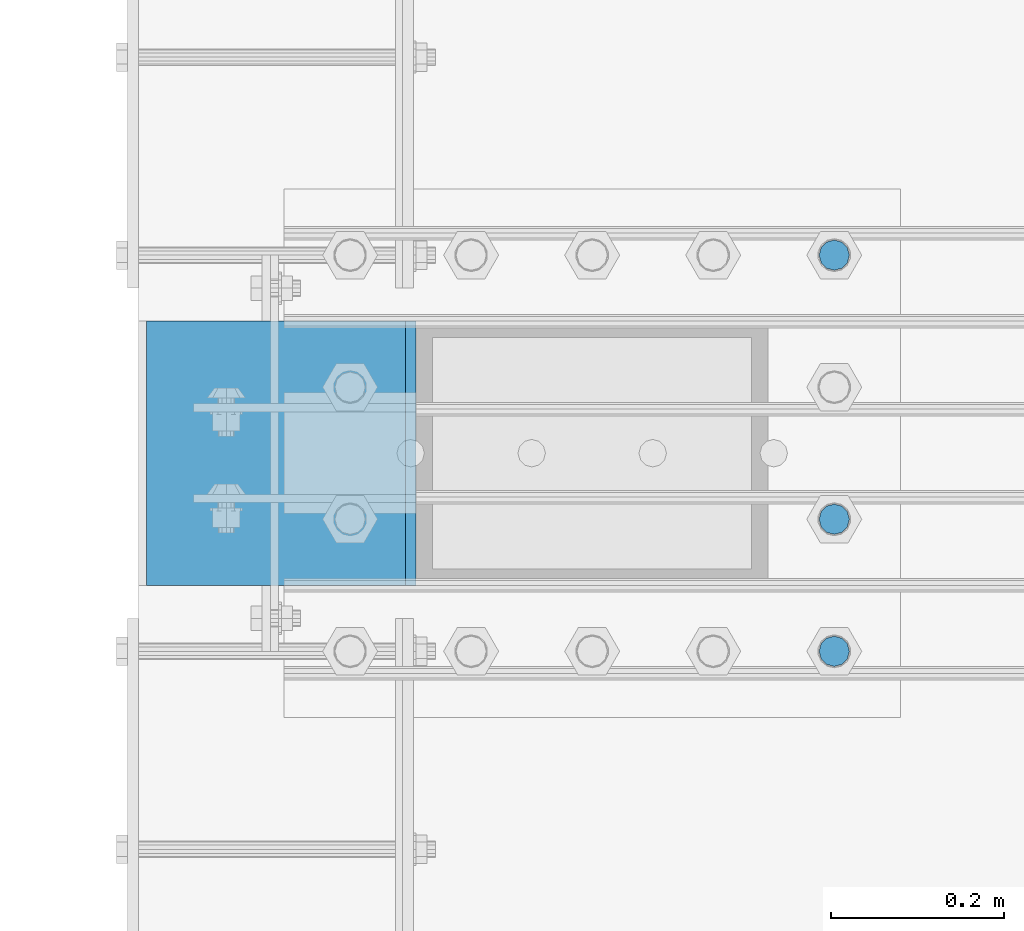
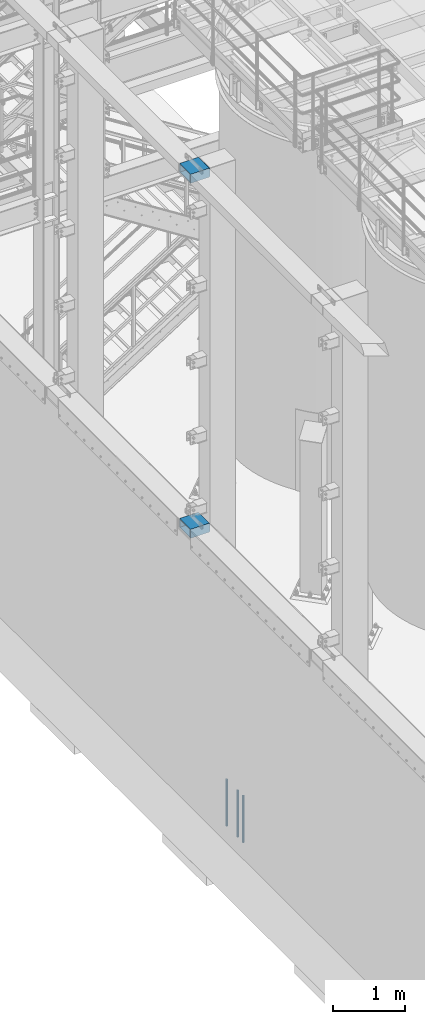
# One storey, part 1098 of 1876: 5 beams, 2 elements without a shape of their own.
"""IFC2X3 building model written with IfcOpenShell, lengths in millimetres."""

from ifc_helpers import new_model, si_unit, frame, origin_with_axes, place, context, subcontext, project, spatial, faceted_brep, material, type_object, element, aggregate, save


model = new_model("IFC2X3")

# Units and contexts
model_context = context("Model", 3, precision=1e-05, world=origin_with_axes())
body_context = subcontext(model_context, "Body", "Model", "MODEL_VIEW")
ifc_project = project(units=[si_unit("LENGTHUNIT", "METRE", prefix="MILLI"), si_unit("AREAUNIT", "SQUARE_METRE"), si_unit("VOLUMEUNIT", "CUBIC_METRE"), si_unit("MASSUNIT", "GRAM", prefix="KILO"), si_unit("TIMEUNIT", "SECOND"), si_unit("PLANEANGLEUNIT", "RADIAN"), si_unit("SOLIDANGLEUNIT", "STERADIAN"), si_unit("THERMODYNAMICTEMPERATUREUNIT", "DEGREE_CELSIUS"), si_unit("LUMINOUSINTENSITYUNIT", "LUMEN")], contexts=[model_context])

# Site, building, storey
site_placement = place(None, origin_with_axes())
site = spatial("IfcSite", under=ifc_project, at=site_placement, CompositionType="ELEMENT")
building_placement = place(site_placement, origin_with_axes())
building = spatial("IfcBuilding", under=site, at=building_placement, Name="Undefined", CompositionType="ELEMENT")
storey_placement = place(building_placement, origin_with_axes())
storey = spatial("IfcBuildingStorey", under=building, at=storey_placement, Name="Undefined", CompositionType="ELEMENT", Elevation=0.0)

# Assembly, beams
assembly_1_placement = place(storey_placement, origin_with_axes())
assembly_1 = element("IfcElementAssembly", 1, at=assembly_1_placement, inside=storey, Name="COLUMN", AssemblyPlace="NOTDEFINED", PredefinedType="RIGID_FRAME")
ifc_material_1 = material()
beam_type_1 = type_object("IfcBeamType", Name="HSS12X6X1/2", PredefinedType="NOTDEFINED")
beam_1_placement = place(assembly_1_placement, frame((-301.625, -14427.2, 10591.8), z_axis=(0.0, 1.0, 0.0), x_axis=(1.0, 0.0, 0.0)))
beam_1 = element("IfcBeam", 2, at=beam_1_placement, type_object=beam_type_1, material=ifc_material_1, Name="BEAM", ObjectType="HSS12X6X1/2", context=body_context, shape_type="Brep", body=[
    faceted_brep([(330.199999999997, 63.4999999999982, 152.4), (330.200000000004, 63.5, 139.7), (330.200000000004, 63.5, -139.7), (330.200000000004, 63.4999999999982, -152.4), (318.105151367185, 76.2000000000007, -152.4), (318.105151367185, 76.2000000000007, 152.4), (19.0499999999993, -76.2000000000007, 152.4), (19.0499999999993, -76.2000000000007, -152.4), (318.105151367185, -76.2000000000007, -152.4), (318.105151367185, -76.2000000000007, 152.4), (19.0499999999993, 76.2000000000007, 152.4), (19.0499999999993, 76.2000000000007, -152.4), (19.0499999999993, 63.5, 139.7), (19.0499999999993, -63.5, 139.7), (19.0499999999993, -63.5, -139.7), (19.0499999999993, 63.5, -139.7), (330.200000000004, -63.5, 139.7), (330.200000000004, -63.5, -139.7), (330.199999999997, -63.4999999999982, 152.4), (330.200000000004, -63.4999999999982, -152.4)], [[[0, 1, 2, 3, 4, 5]], [[6, 7, 8, 9]], [[7, 6, 10, 11], [12, 13, 14, 15]], [[14, 13, 16, 17]], [[18, 9, 8, 19, 17, 16]], [[10, 6, 9, 18, 0, 5]], [[11, 10, 5, 4]], [[19, 8, 7, 11, 4, 3]], [[17, 19, 3, 2]], [[15, 14, 17, 2]], [[12, 15, 2, 1]], [[13, 12, 1, 16]], [[18, 16, 1, 0]]]),
])
beam_2_placement = place(assembly_1_placement, frame((-292.1, -14427.2, 4597.4), z_axis=(0.0, 1.0, 0.0), x_axis=(1.0, 0.0, 0.0)))
beam_2 = element("IfcBeam", 3, at=beam_2_placement, type_object=beam_type_1, material=ifc_material_1, Name="BEAM", ObjectType="HSS12X6X1/2", context=body_context, shape_type="Brep", body=[
    faceted_brep([(320.675000000004, 63.5000000000073, 152.400000000001), (320.675000000004, 63.5, 139.700000000001), (320.675000000004, 63.5, -139.700000000001), (320.675000000004, 63.5000000000073, -152.400000000001), (308.580151367183, 76.1999999999998, -152.4), (308.580151367183, 76.1999999999998, 152.4), (9.52499999999452, -76.1999999999998, 152.400000000001), (9.52499999999452, -76.1999999999998, -152.400000000001), (308.580151367183, -76.1999999999998, -152.4), (308.580151367183, -76.1999999999998, 152.4), (9.52499999999452, 76.1999999999998, 152.400000000001), (9.52499999999452, 76.1999999999998, -152.400000000001), (9.52499999999452, 63.5, 139.700000000001), (9.52499999999452, -63.5, 139.700000000001), (9.52499999999452, -63.5, -139.700000000001), (9.52499999999452, 63.5, -139.700000000001), (320.675000000004, -63.5, 139.700000000001), (320.675000000004, -63.5, -139.700000000001), (320.675000000004, -63.5000000000018, 152.400000000001), (320.675000000004, -63.5000000000018, -152.400000000001)], [[[0, 1, 2, 3, 4, 5]], [[6, 7, 8, 9]], [[7, 6, 10, 11], [12, 13, 14, 15]], [[14, 13, 16, 17]], [[18, 9, 8, 19, 17, 16]], [[10, 6, 9, 18, 0, 5]], [[11, 10, 5, 4]], [[19, 8, 7, 11, 4, 3]], [[3, 2, 17, 19]], [[15, 14, 17, 2]], [[12, 15, 2, 1]], [[13, 12, 1, 16]], [[1, 0, 18, 16]]]),
])
aggregate(assembly_1, [beam_1, beam_2])

assembly_2_placement = place(storey_placement, origin_with_axes())
assembly_2 = element("IfcElementAssembly", 4, at=assembly_2_placement, inside=storey, Name="PLATE", AssemblyPlace="NOTDEFINED", PredefinedType="RIGID_FRAME")
ifc_material_2 = material(Name="STEEL/F1554-55, S1")
beam_type_2 = type_object("IfcBeamType", PredefinedType="NOTDEFINED")
beam_3_placement = place(assembly_2_placement, frame((511.174999999999, -14503.399983724, -50.7999999999993), z_axis=(0.0, -1.0, 0.0), x_axis=(0.0, 0.0, -1.0)))
beam_3 = element("IfcBeam", 5, at=beam_3_placement, type_object=beam_type_2, material=ifc_material_2, Name="WELDED HEADED STUD", context=body_context, shape_type="Brep", body=[
    faceted_brep([(0.0, -17.4625, 0.0), (0.0, -15.1229686135857, -8.73125000000073), (787.399999999999, -15.1229686135857, -8.73125000000073), (787.399999999999, -17.4625, 0.0), (0.0, -8.73124999999999, -15.1229686135848), (787.399999999999, -8.73124999999999, -15.1229686135848), (0.0, 0.0, -17.4625000000015), (787.399999999999, 0.0, -17.4625000000015), (0.0, 8.73124999999999, -15.1229686135848), (787.399999999999, 8.73124999999999, -15.1229686135848), (0.0, 15.1229686135858, -8.73125000000073), (787.399999999999, 15.1229686135858, -8.73125000000073), (0.0, 17.4625, 0.0), (787.399999999999, 17.4625, 0.0), (0.0, 15.1229686135858, 8.73125000000073), (787.399999999999, 15.1229686135858, 8.73125000000073), (0.0, 8.73124999999999, 15.1229686135848), (787.399999999999, 8.73124999999999, 15.1229686135848), (0.0, 0.0, 17.4625000000015), (787.399999999999, 0.0, 17.4625000000015), (0.0, -8.73124999999999, 15.1229686135848), (787.399999999999, -8.73124999999999, 15.1229686135848), (0.0, -15.1229686135858, 8.73125000000073), (787.399999999999, -15.1229686135858, 8.73125000000073)], [[[0, 1, 2, 3]], [[1, 4, 5, 2]], [[4, 6, 7, 5]], [[6, 8, 9, 7]], [[8, 10, 11, 9]], [[10, 12, 13, 11]], [[12, 14, 15, 13]], [[14, 16, 17, 15]], [[16, 18, 19, 17]], [[18, 20, 21, 19]], [[20, 22, 23, 21]], [[22, 0, 3, 23]], [[5, 7, 9, 11, 13, 15, 17, 19, 21, 23, 3, 2]], [[22, 20, 18, 16, 14, 12, 10, 8, 6, 4, 1, 0]]]),
])
beam_4_placement = place(assembly_2_placement, frame((511.174999999999, -14655.7999755859, -50.7999999999993), z_axis=(0.0, -1.0, 0.0), x_axis=(0.0, 0.0, -1.0)))
beam_4 = element("IfcBeam", 6, at=beam_4_placement, type_object=beam_type_2, material=ifc_material_2, Name="WELDED HEADED STUD", context=body_context, shape_type="Brep", body=[
    faceted_brep([(0.0, -17.4625, 0.0), (0.0, -15.1229686135857, -8.73125000000073), (787.399999999999, -15.1229686135857, -8.73125000000073), (787.399999999999, -17.4625, 0.0), (0.0, -8.73124999999999, -15.1229686135848), (787.399999999999, -8.73124999999999, -15.1229686135848), (0.0, 0.0, -17.4625000000015), (787.399999999999, 0.0, -17.4625000000015), (0.0, 8.73124999999999, -15.1229686135848), (787.399999999999, 8.73124999999999, -15.1229686135848), (0.0, 15.1229686135858, -8.73125000000073), (787.399999999999, 15.1229686135858, -8.73125000000073), (0.0, 17.4625, 0.0), (787.399999999999, 17.4625, 0.0), (0.0, 15.1229686135858, 8.73125000000073), (787.399999999999, 15.1229686135858, 8.73125000000073), (0.0, 8.73124999999999, 15.1229686135848), (787.399999999999, 8.73124999999999, 15.1229686135848), (0.0, 0.0, 17.4625000000015), (787.399999999999, 0.0, 17.4625000000015), (0.0, -8.73124999999999, 15.1229686135848), (787.399999999999, -8.73124999999999, 15.1229686135848), (0.0, -15.1229686135858, 8.73125000000073), (787.399999999999, -15.1229686135858, 8.73125000000073)], [[[0, 1, 2, 3]], [[1, 4, 5, 2]], [[4, 6, 7, 5]], [[6, 8, 9, 7]], [[8, 10, 11, 9]], [[10, 12, 13, 11]], [[12, 14, 15, 13]], [[14, 16, 17, 15]], [[16, 18, 19, 17]], [[18, 20, 21, 19]], [[20, 22, 23, 21]], [[22, 0, 3, 23]], [[5, 7, 9, 11, 13, 15, 17, 19, 21, 23, 3, 2]], [[22, 20, 18, 16, 14, 12, 10, 8, 6, 4, 1, 0]]]),
])
beam_5_placement = place(assembly_2_placement, frame((511.174999999999, -14198.6, -50.7999999999993), z_axis=(0.0, -1.0, 0.0), x_axis=(0.0, 0.0, -1.0)))
beam_5 = element("IfcBeam", 7, at=beam_5_placement, type_object=beam_type_2, material=ifc_material_2, Name="WELDED HEADED STUD", context=body_context, shape_type="Brep", body=[
    faceted_brep([(0.0, -17.4625, 0.0), (0.0, -15.1229686135857, -8.73125000000073), (787.399999999999, -15.1229686135857, -8.73125000000073), (787.399999999999, -17.4625, 0.0), (0.0, -8.73124999999999, -15.1229686135848), (787.399999999999, -8.73124999999999, -15.1229686135848), (0.0, 0.0, -17.4625000000015), (787.399999999999, 0.0, -17.4625000000015), (0.0, 8.73124999999999, -15.1229686135848), (787.399999999999, 8.73124999999999, -15.1229686135848), (0.0, 15.1229686135858, -8.73125000000073), (787.399999999999, 15.1229686135858, -8.73125000000073), (0.0, 17.4625, 0.0), (787.399999999999, 17.4625, 0.0), (0.0, 15.1229686135858, 8.73125000000073), (787.399999999999, 15.1229686135858, 8.73125000000073), (0.0, 8.73124999999999, 15.1229686135848), (787.399999999999, 8.73124999999999, 15.1229686135848), (0.0, 0.0, 17.4625000000015), (787.399999999999, 0.0, 17.4625000000015), (0.0, -8.73124999999999, 15.1229686135848), (787.399999999999, -8.73124999999999, 15.1229686135848), (0.0, -15.1229686135858, 8.73125000000073), (787.399999999999, -15.1229686135858, 8.73125000000073)], [[[0, 1, 2, 3]], [[1, 4, 5, 2]], [[4, 6, 7, 5]], [[6, 8, 9, 7]], [[8, 10, 11, 9]], [[10, 12, 13, 11]], [[12, 14, 15, 13]], [[14, 16, 17, 15]], [[16, 18, 19, 17]], [[18, 20, 21, 19]], [[20, 22, 23, 21]], [[22, 0, 3, 23]], [[5, 7, 9, 11, 13, 15, 17, 19, 21, 23, 3, 2]], [[22, 20, 18, 16, 14, 12, 10, 8, 6, 4, 1, 0]]]),
])
aggregate(assembly_2, [beam_3, beam_4, beam_5])

save(model, "model.ifc")
